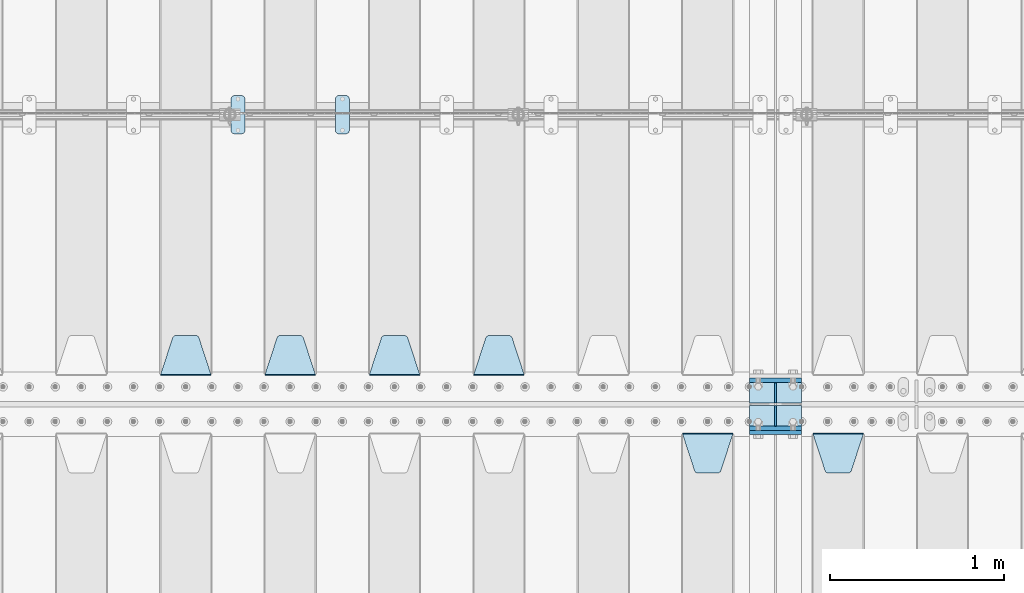
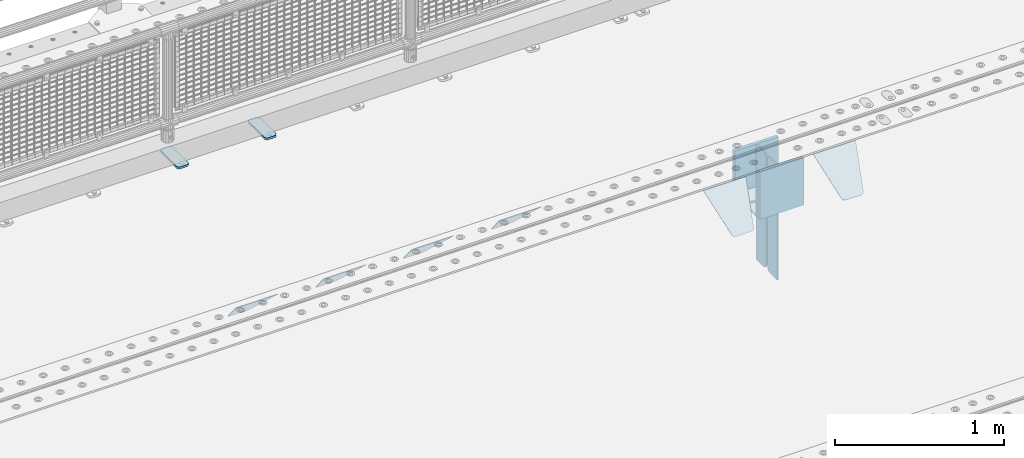
# One storey, part 217 of 240: 17 plates.
"""IFC2X3 building model written with IfcOpenShell, lengths in millimetres."""

from ifc_helpers import new_model, si_unit, frame, origin_with_axes, place, context, subcontext, project, spatial, faceted_brep, material, type_object, element, save


model = new_model("IFC2X3")

# Units and contexts
model_context = context("Model", 3, precision=1e-05, world=origin_with_axes())
body_context = subcontext(model_context, "Body", "Model", "MODEL_VIEW")
ifc_project = project(units=[si_unit("LENGTHUNIT", "METRE", prefix="MILLI"), si_unit("AREAUNIT", "SQUARE_METRE"), si_unit("VOLUMEUNIT", "CUBIC_METRE"), si_unit("MASSUNIT", "GRAM", prefix="KILO"), si_unit("TIMEUNIT", "SECOND"), si_unit("PLANEANGLEUNIT", "RADIAN"), si_unit("SOLIDANGLEUNIT", "STERADIAN"), si_unit("THERMODYNAMICTEMPERATUREUNIT", "DEGREE_CELSIUS"), si_unit("LUMINOUSINTENSITYUNIT", "LUMEN")], contexts=[model_context])

# Site, building, storey
site_placement = place(None, origin_with_axes())
site = spatial("IfcSite", under=ifc_project, at=site_placement, CompositionType="ELEMENT")
building_placement = place(site_placement, origin_with_axes())
building = spatial("IfcBuilding", under=site, at=building_placement, Name="Standard", CompositionType="ELEMENT")
storey_placement = place(building_placement, origin_with_axes())
storey = spatial("IfcBuildingStorey", under=building, at=storey_placement, Name="Undefined", CompositionType="ELEMENT", Elevation=0.0)

# Plates
ifc_material_1 = material(Name="STEEL/S355N")
plate_type_1 = type_object("IfcPlateType", PredefinedType="NOTDEFINED")
plate_1_placement = place(storey_placement, frame((52690.0, 32837.5, -340.000000000044), z_axis=(0.0, 0.0, 1.0), x_axis=(1.0, 0.0, 0.0)))
element("IfcPlate", 1, at=plate_1_placement, inside=storey, type_object=plate_type_1, material=ifc_material_1, context=body_context, shape_type="Brep", body=[
    faceted_brep([(0.0, -12.5, 0.0), (9.31322574615479e-10, -12.5, 340.0), (9.31322574615479e-10, 12.5, 340.0), (0.0, 12.5, 0.0), (300.0, -12.5, 340.0), (300.0, 12.5, 340.0), (300.0, -12.5, 0.0), (300.0, 12.5, 0.0)], [[[0, 1, 2, 3]], [[1, 4, 5, 2]], [[4, 6, 7, 5]], [[6, 0, 3, 7]], [[5, 7, 3, 2]], [[6, 4, 1, 0]]]),
])
for number, where, z_axis, x_axis in (
    (2, (52690.0, 33137.5, -340.0), (0.0, 0.0, 1.0), (1.0, 0.0, 0.0)),
    (3, (52690.0, 32862.5, -340.0), (0.0, 0.0, 1.0), (1.0, 0.0, 0.0)),
):
    element("IfcPlate", number, at=place(storey_placement, frame(where, z_axis=z_axis, x_axis=x_axis)), inside=storey, type_object=plate_type_1, material=ifc_material_1, context=body_context, shape_type="Brep", body=[
        faceted_brep([(0.0, -12.5, 0.0), (0.0, -12.5, 310.0), (0.0, 12.5, 310.0), (0.0, 12.5, 0.0), (300.0, -12.5, 310.0), (300.0, 12.5, 310.0), (300.0, -12.5, 0.0), (300.0, 12.5, 0.0)], [[[0, 1, 2, 3]], [[1, 4, 5, 2]], [[4, 6, 7, 5]], [[6, 0, 3, 7]], [[5, 7, 3, 2]], [[6, 4, 1, 0]]]),
    ])
plate_type_2 = type_object("IfcPlateType", PredefinedType="NOTDEFINED")
for number, where, z_axis, x_axis in (
    (4, (52690.0, 32992.0, -343.0), (0.0, -1.0, 0.0), (1.0, 0.0, 0.0)),
    (5, (52690.0, 33008.0, -343.0), (0.0, 1.0, 0.0), (1.0, 0.0, 0.0)),
):
    element("IfcPlate", number, at=place(storey_placement, frame(where, z_axis=z_axis, x_axis=x_axis)), inside=storey, type_object=plate_type_2, material=ifc_material_1, context=body_context, shape_type="Brep", body=[
        faceted_brep([(0.0, -7.0, 0.0), (0.0, -7.0, 117.0), (0.0, 7.0, 117.0), (0.0, 7.0, 0.0), (300.0, -7.0, 117.0), (300.0, 7.0, 117.0), (300.0, -7.0, 0.0), (300.0, 7.0, 0.0)], [[[0, 1, 2, 3]], [[1, 4, 5, 2]], [[4, 6, 7, 5]], [[6, 0, 3, 7]], [[5, 7, 3, 2]], [[6, 4, 1, 0]]]),
    ])
plate_type_3 = type_object("IfcPlateType", PredefinedType="NOTDEFINED")
for number, where, z_axis, x_axis in (
    (6, (52840.0, 33008.0, -30.0), (0.0, 0.0, -1.0), (0.0, 1.0, 0.0)),
    (7, (52840.0, 32992.0, -30.0), (0.0, 0.0, -1.0), (0.0, -1.0, 0.0)),
):
    element("IfcPlate", number, at=place(storey_placement, frame(where, z_axis=z_axis, x_axis=x_axis)), inside=storey, type_object=plate_type_3, material=ifc_material_1, context=body_context, shape_type="Brep", body=[
        faceted_brep([(0.0, -5.0, 30.0), (0.0, -5.0, 306.0), (0.0, 5.0, 306.0), (0.0, 5.0, 30.0), (117.0, -5.0, 306.0), (117.0, 5.0, 306.0), (117.0, -5.0, 0.0), (117.0, 5.0, 0.0), (30.0, -5.0, 0.0), (30.0, 5.0, 0.0), (24.7905546699913, -5.0, 0.455767409633758), (24.7905546699913, 5.0, 0.455767409633758), (19.7393957002278, -5.0, 1.80922137642275), (19.7393957002278, 5.0, 1.80922137642275), (15.0, -5.0, 4.01923788646684), (15.0, 5.0, 4.01923788646684), (10.7163717094008, -5.0, 7.01866670643066), (10.7163717094008, 5.0, 7.01866670643066), (7.01866670643358, -5.0, 10.7163717094038), (7.01866670643358, 5.0, 10.7163717094038), (4.01923788646673, -5.0, 15.0), (4.01923788646673, 5.0, 15.0), (1.80922137642483, -5.0, 19.7393957002299), (1.80922137642483, 5.0, 19.7393957002299), (0.455767409635882, -5.0, 24.7905546699921), (0.455767409635882, 5.0, 24.7905546699921)], [[[0, 1, 2, 3]], [[1, 4, 5, 2]], [[4, 6, 7, 5]], [[6, 8, 9, 7]], [[8, 10, 11, 9]], [[10, 12, 13, 11]], [[12, 14, 15, 13]], [[14, 16, 17, 15]], [[16, 18, 19, 17]], [[18, 20, 21, 19]], [[20, 22, 23, 21]], [[22, 24, 25, 23]], [[24, 0, 3, 25]], [[5, 7, 9, 11, 13, 15, 17, 19, 21, 23, 25, 3, 2]], [[24, 22, 20, 18, 16, 14, 12, 10, 8, 6, 4, 1, 0]]]),
    ])
for number, where, z_axis, x_axis in (
    (8, (52840.0, 32992.0, -350.0), (0.0, 0.0, -1.0), (0.0, -1.0, 0.0)),
    (9, (52840.0, 33008.0, -350.0), (0.0, 0.0, -1.0), (0.0, 1.0, 0.0)),
):
    element("IfcPlate", number, at=place(storey_placement, frame(where, z_axis=z_axis, x_axis=x_axis)), inside=storey, type_object=plate_type_3, material=ifc_material_1, context=body_context, shape_type="Brep", body=[
        faceted_brep([(0.0, -5.0, 0.0), (0.0, -5.0, 480.0), (0.0, 5.0, 480.0), (0.0, 5.0, 0.0), (0.455767409635882, -5.0, 485.209445330008), (0.455767409635882, 5.0, 485.209445330008), (1.80922137642483, -5.0, 490.26060429977), (1.80922137642483, 5.0, 490.26060429977), (4.01923788646673, -5.0, 495.0), (4.01923788646673, 5.0, 495.0), (7.01866670643358, -5.0, 499.283628290596), (7.01866670643358, 5.0, 499.283628290596), (10.7163717094008, -5.0, 502.981333293569), (10.7163717094008, 5.0, 502.981333293569), (15.0, -5.0, 505.980762113533), (15.0, 5.0, 505.980762113533), (19.7393957002278, -5.0, 508.190778623577), (19.7393957002278, 5.0, 508.190778623577), (24.7905546699913, -5.0, 509.544232590366), (24.7905546699913, 5.0, 509.544232590366), (30.0, -5.0, 510.0), (30.0, 5.0, 510.0), (117.0, -5.0, 510.0), (117.0, 5.0, 510.0), (117.0, -5.0, 0.0), (117.0, 5.0, 0.0)], [[[0, 1, 2, 3]], [[1, 4, 5, 2]], [[4, 6, 7, 5]], [[6, 8, 9, 7]], [[8, 10, 11, 9]], [[10, 12, 13, 11]], [[12, 14, 15, 13]], [[14, 16, 17, 15]], [[16, 18, 19, 17]], [[18, 20, 21, 19]], [[20, 22, 23, 21]], [[22, 24, 25, 23]], [[24, 0, 3, 25]], [[5, 7, 9, 11, 13, 15, 17, 19, 21, 23, 25, 3, 2]], [[24, 22, 20, 18, 16, 14, 12, 10, 8, 6, 4, 1, 0]]]),
    ])
plate_type_4 = type_object("IfcPlateType", PredefinedType="NOTDEFINED")
plate_2_placement = place(storey_placement, frame((53055.0, 32831.767766956, -1.76776695296758), z_axis=(0.0, -0.707106781186547, -0.707106781186548), x_axis=(1.0, 0.0, 0.0)))
element("IfcPlate", 10, at=plate_2_placement, inside=storey, type_object=plate_type_4, material=ifc_material_1, context=body_context, shape_type="Brep", body=[
    faceted_brep([(0.0, -2.5, 0.0), (69.345504679477, -2.50000000000364, 300.171731424827), (69.345504679477, 2.49999999999636, 300.171731424827), (0.0, 2.5, 0.0), (70.927406119954, -2.50000000000364, 304.897442415397), (70.927406119954, 2.49999999999636, 304.897442415397), (73.3818627772271, -2.50000000000728, 309.234538108525), (73.3818627772271, 2.49999999999636, 309.234538108529), (76.6187032999587, -2.50000000000728, 313.023683126099), (76.6187032999587, 2.49999999999636, 313.023683126103), (80.5190132705029, -2.50000000000364, 316.125672595368), (80.5190132705029, 2.49999999999636, 316.125672595368), (84.9395038596849, -2.50000000000364, 318.426546230472), (84.9395038596849, 2.49999999999636, 318.426546230472), (89.7177759439219, -2.5, 319.841774983277), (89.7177759439219, 2.49999999999636, 319.841774983273), (94.6782862926484, -2.50000000000364, 320.319366455074), (94.6782862926484, 2.49999999999636, 320.319366455074), (195.321713707352, -2.50000000000364, 320.319366455074), (195.321713707352, 2.49999999999636, 320.319366455074), (200.282224056078, -2.50000000000364, 319.841774983273), (200.282224056078, 2.49999999999636, 319.841774983273), (205.060496140315, -2.50000000000364, 318.426546230472), (205.060496140315, 2.49999999999636, 318.426546230472), (209.480986729497, -2.50000000000364, 316.125672595368), (209.480986729497, 2.49999999999636, 316.125672595368), (213.381296700041, -2.50000000000728, 313.023683126099), (213.381296700041, 2.49999999999272, 313.023683126099), (216.618137222766, -2.50000000000364, 309.234538108522), (216.618137222766, 2.49999999999636, 309.234538108522), (219.072593880039, -2.50000000000364, 304.897442415397), (219.072593880039, 2.49999999999636, 304.897442415397), (220.654495320523, -2.50000000000364, 300.171731424827), (220.654495320523, 2.49999999999636, 300.171731424827), (290.0, -2.50000000000364, -3.63797880709171e-12), (290.0, 2.49999999999636, -3.63797880709171e-12)], [[[0, 1, 2, 3]], [[1, 4, 5, 2]], [[4, 6, 7, 5]], [[6, 8, 9, 7]], [[8, 10, 11, 9]], [[10, 12, 13, 11]], [[12, 14, 15, 13]], [[14, 16, 17, 15]], [[16, 18, 19, 17]], [[18, 20, 21, 19]], [[20, 22, 23, 21]], [[22, 24, 25, 23]], [[24, 26, 27, 25]], [[26, 28, 29, 27]], [[28, 30, 31, 29]], [[30, 32, 33, 31]], [[32, 34, 35, 33]], [[34, 0, 3, 35]], [[5, 7, 9, 11, 13, 15, 17, 19, 21, 23, 25, 27, 29, 31, 33, 35, 3, 2]], [[34, 32, 30, 28, 26, 24, 22, 20, 18, 16, 14, 12, 10, 8, 6, 4, 1, 0]]]),
])
plate_3_placement = place(storey_placement, frame((52305.0, 32831.767766956, -1.76776695296758), z_axis=(0.0, -0.707106781186547, -0.707106781186548), x_axis=(1.0, 0.0, 0.0)))
element("IfcPlate", 11, at=plate_3_placement, inside=storey, type_object=plate_type_4, material=ifc_material_1, context=body_context, shape_type="Brep", body=[
    faceted_brep([(0.0, -2.5, 0.0), (69.345504679477, -2.50000000000364, 300.171731424827), (69.345504679477, 2.49999999999636, 300.171731424827), (0.0, 2.5, 0.0), (70.927406119954, -2.50000000000364, 304.897442415397), (70.927406119954, 2.49999999999636, 304.897442415397), (73.3818627772271, -2.50000000000728, 309.234538108525), (73.3818627772271, 2.49999999999636, 309.234538108529), (76.6187032999587, -2.50000000000728, 313.023683126099), (76.6187032999587, 2.49999999999636, 313.023683126103), (80.5190132705029, -2.50000000000364, 316.125672595368), (80.5190132705029, 2.49999999999636, 316.125672595368), (84.9395038596849, -2.50000000000364, 318.426546230472), (84.9395038596849, 2.49999999999636, 318.426546230472), (89.7177759439219, -2.5, 319.841774983277), (89.7177759439219, 2.49999999999636, 319.841774983273), (94.6782862926484, -2.50000000000364, 320.319366455074), (94.6782862926484, 2.49999999999636, 320.319366455074), (195.321713707352, -2.50000000000364, 320.319366455074), (195.321713707352, 2.49999999999636, 320.319366455074), (200.282224056078, -2.50000000000364, 319.841774983273), (200.282224056078, 2.49999999999636, 319.841774983273), (205.060496140315, -2.50000000000364, 318.426546230472), (205.060496140315, 2.49999999999636, 318.426546230472), (209.480986729497, -2.50000000000364, 316.125672595368), (209.480986729497, 2.49999999999636, 316.125672595368), (213.381296700041, -2.50000000000728, 313.023683126099), (213.381296700041, 2.49999999999272, 313.023683126099), (216.618137222766, -2.50000000000364, 309.234538108522), (216.618137222766, 2.49999999999636, 309.234538108522), (219.072593880039, -2.50000000000364, 304.897442415397), (219.072593880039, 2.49999999999636, 304.897442415397), (220.654495320523, -2.50000000000364, 300.171731424827), (220.654495320523, 2.49999999999636, 300.171731424827), (290.0, -2.50000000000364, -3.63797880709171e-12), (290.0, 2.49999999999636, -3.63797880709171e-12)], [[[0, 1, 2, 3]], [[1, 4, 5, 2]], [[4, 6, 7, 5]], [[6, 8, 9, 7]], [[8, 10, 11, 9]], [[10, 12, 13, 11]], [[12, 14, 15, 13]], [[14, 16, 17, 15]], [[16, 18, 19, 17]], [[18, 20, 21, 19]], [[20, 22, 23, 21]], [[22, 24, 25, 23]], [[24, 26, 27, 25]], [[26, 28, 29, 27]], [[28, 30, 31, 29]], [[30, 32, 33, 31]], [[32, 34, 35, 33]], [[34, 0, 3, 35]], [[5, 7, 9, 11, 13, 15, 17, 19, 21, 23, 25, 27, 29, 31, 33, 35, 3, 2]], [[34, 32, 30, 28, 26, 24, 22, 20, 18, 16, 14, 12, 10, 8, 6, 4, 1, 0]]]),
])
plate_4_placement = place(storey_placement, frame((51395.0, 33168.232233047, -1.76776695296758), z_axis=(0.0, 0.707106781186547, -0.707106781186548), x_axis=(-1.0, 0.0, 0.0)))
element("IfcPlate", 12, at=plate_4_placement, inside=storey, type_object=plate_type_4, material=ifc_material_1, context=body_context, shape_type="Brep", body=[
    faceted_brep([(0.0, -2.5, 0.0), (69.345504679477, -2.50000000000364, 300.171731424827), (69.345504679477, 2.49999999999636, 300.171731424827), (0.0, 2.5, 0.0), (70.927406119954, -2.50000000000364, 304.897442415397), (70.927406119954, 2.49999999999636, 304.897442415397), (73.3818627772271, -2.50000000000728, 309.234538108525), (73.3818627772271, 2.49999999999636, 309.234538108529), (76.6187032999587, -2.50000000000728, 313.023683126099), (76.6187032999587, 2.49999999999636, 313.023683126103), (80.5190132705029, -2.50000000000364, 316.125672595368), (80.5190132705029, 2.49999999999636, 316.125672595368), (84.9395038596849, -2.50000000000364, 318.426546230472), (84.9395038596849, 2.49999999999636, 318.426546230472), (89.7177759439219, -2.5, 319.841774983277), (89.7177759439219, 2.49999999999636, 319.841774983273), (94.6782862926484, -2.50000000000364, 320.319366455074), (94.6782862926484, 2.49999999999636, 320.319366455074), (195.321713707352, -2.50000000000364, 320.319366455074), (195.321713707352, 2.49999999999636, 320.319366455074), (200.282224056078, -2.50000000000364, 319.841774983273), (200.282224056078, 2.49999999999636, 319.841774983273), (205.060496140315, -2.50000000000364, 318.426546230472), (205.060496140315, 2.49999999999636, 318.426546230472), (209.480986729497, -2.50000000000364, 316.125672595368), (209.480986729497, 2.49999999999636, 316.125672595368), (213.381296700041, -2.50000000000728, 313.023683126099), (213.381296700041, 2.49999999999272, 313.023683126099), (216.618137222766, -2.50000000000364, 309.234538108522), (216.618137222766, 2.49999999999636, 309.234538108522), (219.072593880039, -2.50000000000364, 304.897442415397), (219.072593880039, 2.49999999999636, 304.897442415397), (220.654495320523, -2.50000000000364, 300.171731424827), (220.654495320523, 2.49999999999636, 300.171731424827), (290.0, -2.50000000000364, -3.63797880709171e-12), (290.0, 2.49999999999636, -3.63797880709171e-12)], [[[0, 1, 2, 3]], [[1, 4, 5, 2]], [[4, 6, 7, 5]], [[6, 8, 9, 7]], [[8, 10, 11, 9]], [[10, 12, 13, 11]], [[12, 14, 15, 13]], [[14, 16, 17, 15]], [[16, 18, 19, 17]], [[18, 20, 21, 19]], [[20, 22, 23, 21]], [[22, 24, 25, 23]], [[24, 26, 27, 25]], [[26, 28, 29, 27]], [[28, 30, 31, 29]], [[30, 32, 33, 31]], [[32, 34, 35, 33]], [[34, 0, 3, 35]], [[5, 7, 9, 11, 13, 15, 17, 19, 21, 23, 25, 27, 29, 31, 33, 35, 3, 2]], [[34, 32, 30, 28, 26, 24, 22, 20, 18, 16, 14, 12, 10, 8, 6, 4, 1, 0]]]),
])
plate_5_placement = place(storey_placement, frame((50795.0, 33168.232233047, -1.76776695296758), z_axis=(0.0, 0.707106781186547, -0.707106781186548), x_axis=(-1.0, 0.0, 0.0)))
element("IfcPlate", 13, at=plate_5_placement, inside=storey, type_object=plate_type_4, material=ifc_material_1, context=body_context, shape_type="Brep", body=[
    faceted_brep([(0.0, -2.5, 0.0), (69.345504679477, -2.50000000000364, 300.171731424827), (69.345504679477, 2.49999999999636, 300.171731424827), (0.0, 2.5, 0.0), (70.927406119954, -2.50000000000364, 304.897442415397), (70.927406119954, 2.49999999999636, 304.897442415397), (73.3818627772271, -2.50000000000728, 309.234538108525), (73.3818627772271, 2.49999999999636, 309.234538108529), (76.6187032999587, -2.50000000000728, 313.023683126099), (76.6187032999587, 2.49999999999636, 313.023683126103), (80.5190132705029, -2.50000000000364, 316.125672595368), (80.5190132705029, 2.49999999999636, 316.125672595368), (84.9395038596849, -2.50000000000364, 318.426546230472), (84.9395038596849, 2.49999999999636, 318.426546230472), (89.7177759439219, -2.5, 319.841774983277), (89.7177759439219, 2.49999999999636, 319.841774983273), (94.6782862926484, -2.50000000000364, 320.319366455074), (94.6782862926484, 2.49999999999636, 320.319366455074), (195.321713707352, -2.50000000000364, 320.319366455074), (195.321713707352, 2.49999999999636, 320.319366455074), (200.282224056078, -2.50000000000364, 319.841774983273), (200.282224056078, 2.49999999999636, 319.841774983273), (205.060496140315, -2.50000000000364, 318.426546230472), (205.060496140315, 2.49999999999636, 318.426546230472), (209.480986729497, -2.50000000000364, 316.125672595368), (209.480986729497, 2.49999999999636, 316.125672595368), (213.381296700041, -2.50000000000728, 313.023683126099), (213.381296700041, 2.49999999999272, 313.023683126099), (216.618137222766, -2.50000000000364, 309.234538108522), (216.618137222766, 2.49999999999636, 309.234538108522), (219.072593880039, -2.50000000000364, 304.897442415397), (219.072593880039, 2.49999999999636, 304.897442415397), (220.654495320523, -2.50000000000364, 300.171731424827), (220.654495320523, 2.49999999999636, 300.171731424827), (290.0, -2.50000000000364, -3.63797880709171e-12), (290.0, 2.49999999999636, -3.63797880709171e-12)], [[[0, 1, 2, 3]], [[1, 4, 5, 2]], [[4, 6, 7, 5]], [[6, 8, 9, 7]], [[8, 10, 11, 9]], [[10, 12, 13, 11]], [[12, 14, 15, 13]], [[14, 16, 17, 15]], [[16, 18, 19, 17]], [[18, 20, 21, 19]], [[20, 22, 23, 21]], [[22, 24, 25, 23]], [[24, 26, 27, 25]], [[26, 28, 29, 27]], [[28, 30, 31, 29]], [[30, 32, 33, 31]], [[32, 34, 35, 33]], [[34, 0, 3, 35]], [[5, 7, 9, 11, 13, 15, 17, 19, 21, 23, 25, 27, 29, 31, 33, 35, 3, 2]], [[34, 32, 30, 28, 26, 24, 22, 20, 18, 16, 14, 12, 10, 8, 6, 4, 1, 0]]]),
])
plate_6_placement = place(storey_placement, frame((50195.0, 33168.232233047, -1.76776695296758), z_axis=(0.0, 0.707106781186547, -0.707106781186548), x_axis=(-1.0, 0.0, 0.0)))
element("IfcPlate", 14, at=plate_6_placement, inside=storey, type_object=plate_type_4, material=ifc_material_1, context=body_context, shape_type="Brep", body=[
    faceted_brep([(0.0, -2.5, 0.0), (69.345504679477, -2.50000000000364, 300.171731424827), (69.345504679477, 2.49999999999636, 300.171731424827), (0.0, 2.5, 0.0), (70.927406119954, -2.50000000000364, 304.897442415397), (70.927406119954, 2.49999999999636, 304.897442415397), (73.3818627772271, -2.50000000000728, 309.234538108525), (73.3818627772271, 2.49999999999636, 309.234538108529), (76.6187032999587, -2.50000000000728, 313.023683126099), (76.6187032999587, 2.49999999999636, 313.023683126103), (80.5190132705029, -2.50000000000364, 316.125672595368), (80.5190132705029, 2.49999999999636, 316.125672595368), (84.9395038596849, -2.50000000000364, 318.426546230472), (84.9395038596849, 2.49999999999636, 318.426546230472), (89.7177759439219, -2.5, 319.841774983277), (89.7177759439219, 2.49999999999636, 319.841774983273), (94.6782862926484, -2.50000000000364, 320.319366455074), (94.6782862926484, 2.49999999999636, 320.319366455074), (195.321713707352, -2.50000000000364, 320.319366455074), (195.321713707352, 2.49999999999636, 320.319366455074), (200.282224056078, -2.50000000000364, 319.841774983273), (200.282224056078, 2.49999999999636, 319.841774983273), (205.060496140315, -2.50000000000364, 318.426546230472), (205.060496140315, 2.49999999999636, 318.426546230472), (209.480986729497, -2.50000000000364, 316.125672595368), (209.480986729497, 2.49999999999636, 316.125672595368), (213.381296700041, -2.50000000000728, 313.023683126099), (213.381296700041, 2.49999999999272, 313.023683126099), (216.618137222766, -2.50000000000364, 309.234538108522), (216.618137222766, 2.49999999999636, 309.234538108522), (219.072593880039, -2.50000000000364, 304.897442415397), (219.072593880039, 2.49999999999636, 304.897442415397), (220.654495320523, -2.50000000000364, 300.171731424827), (220.654495320523, 2.49999999999636, 300.171731424827), (290.0, -2.50000000000364, -3.63797880709171e-12), (290.0, 2.49999999999636, -3.63797880709171e-12)], [[[0, 1, 2, 3]], [[1, 4, 5, 2]], [[4, 6, 7, 5]], [[6, 8, 9, 7]], [[8, 10, 11, 9]], [[10, 12, 13, 11]], [[12, 14, 15, 13]], [[14, 16, 17, 15]], [[16, 18, 19, 17]], [[18, 20, 21, 19]], [[20, 22, 23, 21]], [[22, 24, 25, 23]], [[24, 26, 27, 25]], [[26, 28, 29, 27]], [[28, 30, 31, 29]], [[30, 32, 33, 31]], [[32, 34, 35, 33]], [[34, 0, 3, 35]], [[5, 7, 9, 11, 13, 15, 17, 19, 21, 23, 25, 27, 29, 31, 33, 35, 3, 2]], [[34, 32, 30, 28, 26, 24, 22, 20, 18, 16, 14, 12, 10, 8, 6, 4, 1, 0]]]),
])
plate_7_placement = place(storey_placement, frame((49595.0, 33168.232233047, -1.76776695296758), z_axis=(0.0, 0.707106781186547, -0.707106781186548), x_axis=(-1.0, 0.0, 0.0)))
element("IfcPlate", 15, at=plate_7_placement, inside=storey, type_object=plate_type_4, material=ifc_material_1, context=body_context, shape_type="Brep", body=[
    faceted_brep([(0.0, -2.5, 0.0), (69.345504679477, -2.50000000000364, 300.171731424827), (69.345504679477, 2.49999999999636, 300.171731424827), (0.0, 2.5, 0.0), (70.927406119954, -2.50000000000364, 304.897442415397), (70.927406119954, 2.49999999999636, 304.897442415397), (73.3818627772271, -2.50000000000728, 309.234538108525), (73.3818627772271, 2.49999999999636, 309.234538108529), (76.6187032999587, -2.50000000000728, 313.023683126099), (76.6187032999587, 2.49999999999636, 313.023683126103), (80.5190132705029, -2.50000000000364, 316.125672595368), (80.5190132705029, 2.49999999999636, 316.125672595368), (84.9395038596849, -2.50000000000364, 318.426546230472), (84.9395038596849, 2.49999999999636, 318.426546230472), (89.7177759439219, -2.5, 319.841774983277), (89.7177759439219, 2.49999999999636, 319.841774983273), (94.6782862926484, -2.50000000000364, 320.319366455074), (94.6782862926484, 2.49999999999636, 320.319366455074), (195.321713707352, -2.50000000000364, 320.319366455074), (195.321713707352, 2.49999999999636, 320.319366455074), (200.282224056078, -2.50000000000364, 319.841774983273), (200.282224056078, 2.49999999999636, 319.841774983273), (205.060496140315, -2.50000000000364, 318.426546230472), (205.060496140315, 2.49999999999636, 318.426546230472), (209.480986729497, -2.50000000000364, 316.125672595368), (209.480986729497, 2.49999999999636, 316.125672595368), (213.381296700041, -2.50000000000728, 313.023683126099), (213.381296700041, 2.49999999999272, 313.023683126099), (216.618137222766, -2.50000000000364, 309.234538108522), (216.618137222766, 2.49999999999636, 309.234538108522), (219.072593880039, -2.50000000000364, 304.897442415397), (219.072593880039, 2.49999999999636, 304.897442415397), (220.654495320523, -2.50000000000364, 300.171731424827), (220.654495320523, 2.49999999999636, 300.171731424827), (290.0, -2.50000000000364, -3.63797880709171e-12), (290.0, 2.49999999999636, -3.63797880709171e-12)], [[[0, 1, 2, 3]], [[1, 4, 5, 2]], [[4, 6, 7, 5]], [[6, 8, 9, 7]], [[8, 10, 11, 9]], [[10, 12, 13, 11]], [[12, 14, 15, 13]], [[14, 16, 17, 15]], [[16, 18, 19, 17]], [[18, 20, 21, 19]], [[20, 22, 23, 21]], [[22, 24, 25, 23]], [[24, 26, 27, 25]], [[26, 28, 29, 27]], [[28, 30, 31, 29]], [[30, 32, 33, 31]], [[32, 34, 35, 33]], [[34, 0, 3, 35]], [[5, 7, 9, 11, 13, 15, 17, 19, 21, 23, 25, 27, 29, 31, 33, 35, 3, 2]], [[34, 32, 30, 28, 26, 24, 22, 20, 18, 16, 14, 12, 10, 8, 6, 4, 1, 0]]]),
])
ifc_material_2 = material(Name="STEEL/S355J2")
plate_type_5 = type_object("IfcPlateType", PredefinedType="NOTDEFINED")
plate_8_placement = place(storey_placement, frame((50310.0, 34774.5, 21.0199999999977), z_axis=(1.0, 0.0, 0.0), x_axis=(0.0, -1.0, 0.0)))
element("IfcPlate", 16, at=plate_8_placement, inside=storey, type_object=plate_type_5, material=ifc_material_2, context=body_context, shape_type="Brep", body=[
    faceted_brep([(0.0, -7.0, 20.0), (0.0, -7.0, 60.0), (0.0, 7.0, 60.0), (0.0, 7.0, 20.0), (0.384294391937146, -7.0, 63.9018064403208), (0.384294391937146, 7.0, 63.9018064403208), (1.52240934977453, -7.0, 67.6536686473046), (1.52240934977453, 7.0, 67.6536686473046), (3.37060775394639, -7.0, 71.1114046603907), (3.37060775394639, 7.0, 71.1114046603907), (5.85786437626666, -7.0, 74.1421356237333), (5.85786437626666, 7.0, 74.1421356237333), (8.88859533960931, -7.0, 76.6293922460536), (8.88859533960931, 7.0, 76.6293922460536), (12.3463313526954, -7.0, 78.4775906502255), (12.3463313526954, 7.0, 78.4775906502255), (16.0981935596792, -7.0, 79.6157056080629), (16.0981935596792, 7.0, 79.6157056080629), (20.0, -7.0, 80.0), (20.0, 7.0, 80.0), (200.0, -7.0, 80.0), (200.0, 7.0, 80.0), (203.901806440321, -7.0, 79.6157056080629), (203.901806440321, 7.0, 79.6157056080629), (207.653668647305, -7.0, 78.4775906502255), (207.653668647305, 7.0, 78.4775906502255), (211.111404660391, -7.0, 76.6293922460536), (211.111404660391, 7.0, 76.6293922460536), (214.142135623733, -7.0, 74.1421356237333), (214.142135623733, 7.0, 74.1421356237333), (216.629392246054, -7.0, 71.1114046603907), (216.629392246054, 7.0, 71.1114046603907), (218.477590650225, -7.0, 67.6536686473046), (218.477590650225, 7.0, 67.6536686473046), (219.615705608063, -7.0, 63.9018064403208), (219.615705608063, 7.0, 63.9018064403208), (220.0, -7.0, 60.0), (220.0, 7.0, 60.0), (220.0, -7.0, 20.0), (220.0, 7.0, 20.0), (219.615705608063, -7.0, 16.0981935596792), (219.615705608063, 7.0, 16.0981935596792), (218.477590650225, -7.0, 12.3463313526954), (218.477590650225, 7.0, 12.3463313526954), (216.629392246054, -7.0, 8.88859533960931), (216.629392246054, 7.0, 8.88859533960931), (214.142135623733, -7.0, 5.85786437626666), (214.142135623733, 7.0, 5.85786437626666), (211.111404660391, -7.0, 3.37060775394639), (211.111404660391, 7.0, 3.37060775394639), (207.653668647305, -7.0, 1.52240934977453), (207.653668647305, 7.0, 1.52240934977453), (203.901806440321, -7.0, 0.384294391937146), (203.901806440321, 7.0, 0.384294391937146), (200.0, -7.0, 0.0), (200.0, 7.0, 0.0), (20.0, -7.0, 0.0), (20.0, 7.0, 0.0), (16.0981935596792, -7.0, 0.384294391937146), (16.0981935596792, 7.0, 0.384294391937146), (12.3463313526954, -7.0, 1.52240934977453), (12.3463313526954, 7.0, 1.52240934977453), (8.88859533960931, -7.0, 3.37060775394639), (8.88859533960931, 7.0, 3.37060775394639), (5.85786437626666, -7.0, 5.85786437626666), (5.85786437626666, 7.0, 5.85786437626666), (3.37060775394639, -7.0, 8.88859533960931), (3.37060775394639, 7.0, 8.88859533960931), (1.52240934977453, -7.0, 12.3463313526954), (1.52240934977453, 7.0, 12.3463313526954), (0.384294391937146, -7.0, 16.0981935596792), (0.384294391937146, 7.0, 16.0981935596792)], [[[0, 1, 2, 3]], [[1, 4, 5, 2]], [[4, 6, 7, 5]], [[6, 8, 9, 7]], [[8, 10, 11, 9]], [[10, 12, 13, 11]], [[12, 14, 15, 13]], [[14, 16, 17, 15]], [[16, 18, 19, 17]], [[18, 20, 21, 19]], [[20, 22, 23, 21]], [[22, 24, 25, 23]], [[24, 26, 27, 25]], [[26, 28, 29, 27]], [[28, 30, 31, 29]], [[30, 32, 33, 31]], [[32, 34, 35, 33]], [[34, 36, 37, 35]], [[36, 38, 39, 37]], [[38, 40, 41, 39]], [[40, 42, 43, 41]], [[42, 44, 45, 43]], [[44, 46, 47, 45]], [[46, 48, 49, 47]], [[48, 50, 51, 49]], [[50, 52, 53, 51]], [[52, 54, 55, 53]], [[54, 56, 57, 55]], [[56, 58, 59, 57]], [[58, 60, 61, 59]], [[60, 62, 63, 61]], [[62, 64, 65, 63]], [[64, 66, 67, 65]], [[66, 68, 69, 67]], [[68, 70, 71, 69]], [[70, 0, 3, 71]], [[5, 7, 9, 11, 13, 15, 17, 19, 21, 23, 25, 27, 29, 31, 33, 35, 37, 39, 41, 43, 45, 47, 49, 51, 53, 55, 57, 59, 61, 63, 65, 67, 69, 71, 3, 2]], [[70, 68, 66, 64, 62, 60, 58, 56, 54, 52, 50, 48, 46, 44, 42, 40, 38, 36, 34, 32, 30, 28, 26, 24, 22, 20, 18, 16, 14, 12, 10, 8, 6, 4, 1, 0]]]),
])
plate_9_placement = place(storey_placement, frame((49710.0, 34774.5, 21.0199999999977), z_axis=(1.0, 0.0, 0.0), x_axis=(0.0, -1.0, 0.0)))
element("IfcPlate", 17, at=plate_9_placement, inside=storey, type_object=plate_type_5, material=ifc_material_2, context=body_context, shape_type="Brep", body=[
    faceted_brep([(0.0, -7.0, 20.0), (0.0, -7.0, 60.0), (0.0, 7.0, 60.0), (0.0, 7.0, 20.0), (0.384294391937146, -7.0, 63.9018064403208), (0.384294391937146, 7.0, 63.9018064403208), (1.52240934977453, -7.0, 67.6536686473046), (1.52240934977453, 7.0, 67.6536686473046), (3.37060775394639, -7.0, 71.1114046603907), (3.37060775394639, 7.0, 71.1114046603907), (5.85786437626666, -7.0, 74.1421356237333), (5.85786437626666, 7.0, 74.1421356237333), (8.88859533960931, -7.0, 76.6293922460536), (8.88859533960931, 7.0, 76.6293922460536), (12.3463313526954, -7.0, 78.4775906502255), (12.3463313526954, 7.0, 78.4775906502255), (16.0981935596792, -7.0, 79.6157056080629), (16.0981935596792, 7.0, 79.6157056080629), (20.0, -7.0, 80.0), (20.0, 7.0, 80.0), (200.0, -7.0, 80.0), (200.0, 7.0, 80.0), (203.901806440321, -7.0, 79.6157056080629), (203.901806440321, 7.0, 79.6157056080629), (207.653668647305, -7.0, 78.4775906502255), (207.653668647305, 7.0, 78.4775906502255), (211.111404660391, -7.0, 76.6293922460536), (211.111404660391, 7.0, 76.6293922460536), (214.142135623733, -7.0, 74.1421356237333), (214.142135623733, 7.0, 74.1421356237333), (216.629392246054, -7.0, 71.1114046603907), (216.629392246054, 7.0, 71.1114046603907), (218.477590650225, -7.0, 67.6536686473046), (218.477590650225, 7.0, 67.6536686473046), (219.615705608063, -7.0, 63.9018064403208), (219.615705608063, 7.0, 63.9018064403208), (220.0, -7.0, 60.0), (220.0, 7.0, 60.0), (220.0, -7.0, 20.0), (220.0, 7.0, 20.0), (219.615705608063, -7.0, 16.0981935596792), (219.615705608063, 7.0, 16.0981935596792), (218.477590650225, -7.0, 12.3463313526954), (218.477590650225, 7.0, 12.3463313526954), (216.629392246054, -7.0, 8.88859533960931), (216.629392246054, 7.0, 8.88859533960931), (214.142135623733, -7.0, 5.85786437626666), (214.142135623733, 7.0, 5.85786437626666), (211.111404660391, -7.0, 3.37060775394639), (211.111404660391, 7.0, 3.37060775394639), (207.653668647305, -7.0, 1.52240934977453), (207.653668647305, 7.0, 1.52240934977453), (203.901806440321, -7.0, 0.384294391937146), (203.901806440321, 7.0, 0.384294391937146), (200.0, -7.0, 0.0), (200.0, 7.0, 0.0), (20.0, -7.0, 0.0), (20.0, 7.0, 0.0), (16.0981935596792, -7.0, 0.384294391937146), (16.0981935596792, 7.0, 0.384294391937146), (12.3463313526954, -7.0, 1.52240934977453), (12.3463313526954, 7.0, 1.52240934977453), (8.88859533960931, -7.0, 3.37060775394639), (8.88859533960931, 7.0, 3.37060775394639), (5.85786437626666, -7.0, 5.85786437626666), (5.85786437626666, 7.0, 5.85786437626666), (3.37060775394639, -7.0, 8.88859533960931), (3.37060775394639, 7.0, 8.88859533960931), (1.52240934977453, -7.0, 12.3463313526954), (1.52240934977453, 7.0, 12.3463313526954), (0.384294391937146, -7.0, 16.0981935596792), (0.384294391937146, 7.0, 16.0981935596792)], [[[0, 1, 2, 3]], [[1, 4, 5, 2]], [[4, 6, 7, 5]], [[6, 8, 9, 7]], [[8, 10, 11, 9]], [[10, 12, 13, 11]], [[12, 14, 15, 13]], [[14, 16, 17, 15]], [[16, 18, 19, 17]], [[18, 20, 21, 19]], [[20, 22, 23, 21]], [[22, 24, 25, 23]], [[24, 26, 27, 25]], [[26, 28, 29, 27]], [[28, 30, 31, 29]], [[30, 32, 33, 31]], [[32, 34, 35, 33]], [[34, 36, 37, 35]], [[36, 38, 39, 37]], [[38, 40, 41, 39]], [[40, 42, 43, 41]], [[42, 44, 45, 43]], [[44, 46, 47, 45]], [[46, 48, 49, 47]], [[48, 50, 51, 49]], [[50, 52, 53, 51]], [[52, 54, 55, 53]], [[54, 56, 57, 55]], [[56, 58, 59, 57]], [[58, 60, 61, 59]], [[60, 62, 63, 61]], [[62, 64, 65, 63]], [[64, 66, 67, 65]], [[66, 68, 69, 67]], [[68, 70, 71, 69]], [[70, 0, 3, 71]], [[5, 7, 9, 11, 13, 15, 17, 19, 21, 23, 25, 27, 29, 31, 33, 35, 37, 39, 41, 43, 45, 47, 49, 51, 53, 55, 57, 59, 61, 63, 65, 67, 69, 71, 3, 2]], [[70, 68, 66, 64, 62, 60, 58, 56, 54, 52, 50, 48, 46, 44, 42, 40, 38, 36, 34, 32, 30, 28, 26, 24, 22, 20, 18, 16, 14, 12, 10, 8, 6, 4, 1, 0]]]),
])

save(model, "model.ifc")
